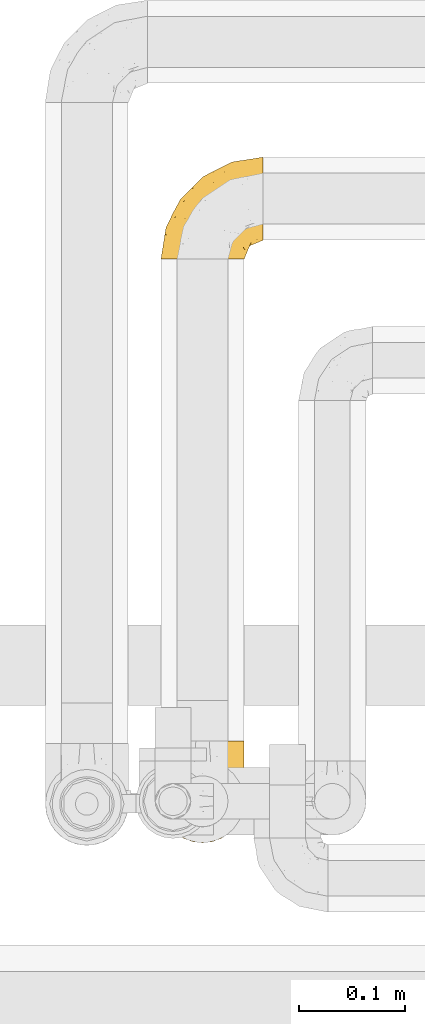
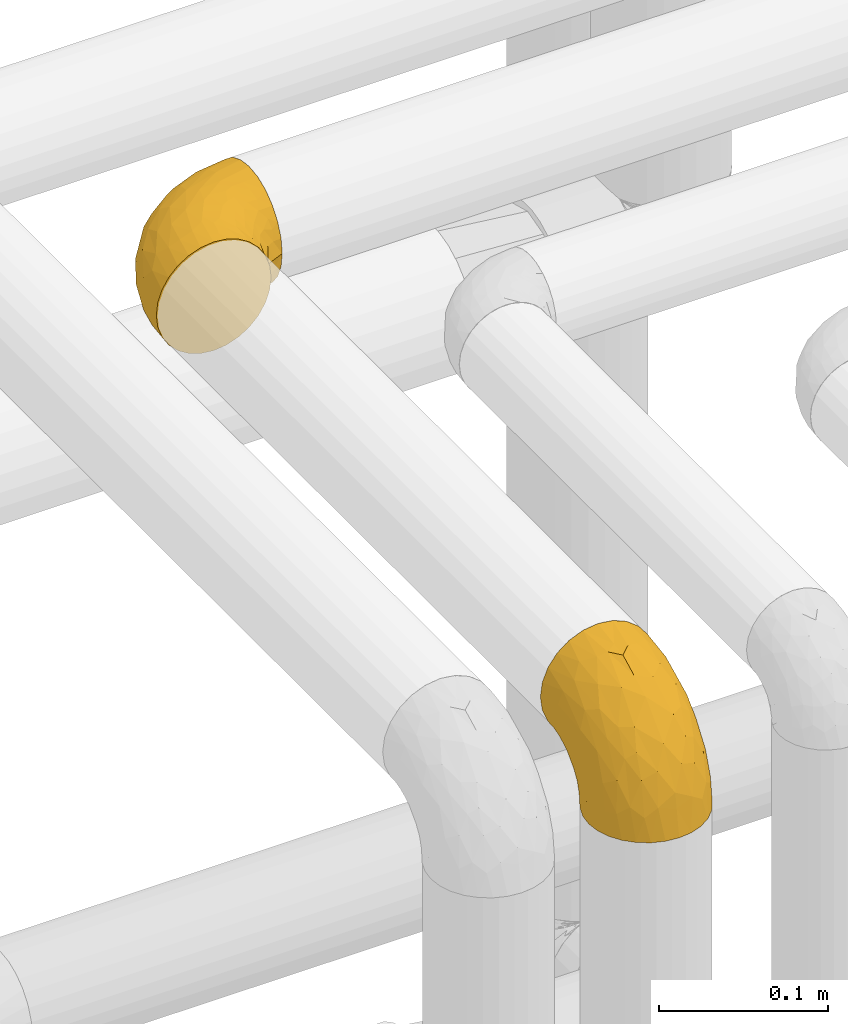
# One storey, part 449 of 827: 2 coverings.
"""IFC2X3 building model written with IfcOpenShell, lengths in millimetres."""

from ifc_helpers import new_model, entity, si_unit, converted_unit, derived_unit, direction, frame, origin, place, context, subcontext, project, spatial, faceted_brep, element, save


model = new_model("IFC2X3")

# Units and contexts
model_context = context("Model", 3, precision=0.01, world=origin(), true_north=direction((6.12303176911189e-17, 1.0)))
body_context = subcontext(model_context, "Body", "Model", "MODEL_VIEW")
ifc_project = project(units=[si_unit("LENGTHUNIT", "METRE", prefix="MILLI"), si_unit("AREAUNIT", "SQUARE_METRE"), si_unit("VOLUMEUNIT", "CUBIC_METRE"), converted_unit("PLANEANGLEUNIT", "DEGREE", entity("IfcRatioMeasure", 0.0174532925199433), si_unit("PLANEANGLEUNIT", "RADIAN"), dimensions=[0, 0, 0, 0, 0, 0, 0]), si_unit("MASSUNIT", "GRAM", prefix="KILO"), derived_unit("MASSDENSITYUNIT", [(si_unit("MASSUNIT", "GRAM", prefix="KILO"), 1), (si_unit("LENGTHUNIT", "METRE"), -3)]), derived_unit("MOMENTOFINERTIAUNIT", [(si_unit("LENGTHUNIT", "METRE"), 4)]), si_unit("TIMEUNIT", "SECOND"), si_unit("FREQUENCYUNIT", "HERTZ"), si_unit("THERMODYNAMICTEMPERATUREUNIT", "DEGREE_CELSIUS"), derived_unit("THERMALTRANSMITTANCEUNIT", [(si_unit("MASSUNIT", "GRAM", prefix="KILO"), 1), (si_unit("THERMODYNAMICTEMPERATUREUNIT", "KELVIN"), -1), (si_unit("TIMEUNIT", "SECOND"), -3)]), derived_unit("VOLUMETRICFLOWRATEUNIT", [(si_unit("LENGTHUNIT", "METRE"), 3), (si_unit("TIMEUNIT", "SECOND"), -1)]), derived_unit("MASSFLOWRATEUNIT", [(si_unit("MASSUNIT", "GRAM", prefix="KILO"), 1), (si_unit("TIMEUNIT", "SECOND"), -1)]), derived_unit("ROTATIONALFREQUENCYUNIT", [(si_unit("TIMEUNIT", "SECOND"), -1)]), si_unit("ELECTRICCURRENTUNIT", "AMPERE"), si_unit("ELECTRICVOLTAGEUNIT", "VOLT"), si_unit("POWERUNIT", "WATT"), si_unit("FORCEUNIT", "NEWTON", prefix="KILO"), si_unit("ILLUMINANCEUNIT", "LUX"), si_unit("LUMINOUSFLUXUNIT", "LUMEN"), si_unit("LUMINOUSINTENSITYUNIT", "CANDELA"), derived_unit("USERDEFINED", [(si_unit("MASSUNIT", "GRAM", prefix="KILO"), -1), (si_unit("LENGTHUNIT", "METRE"), -2), (si_unit("TIMEUNIT", "SECOND"), 3), (si_unit("LUMINOUSFLUXUNIT", "LUMEN"), 1)]), derived_unit("LINEARVELOCITYUNIT", [(si_unit("LENGTHUNIT", "METRE"), 1), (si_unit("TIMEUNIT", "SECOND"), -1)]), si_unit("PRESSUREUNIT", "PASCAL"), derived_unit("USERDEFINED", [(si_unit("LENGTHUNIT", "METRE"), -2), (si_unit("MASSUNIT", "GRAM", prefix="KILO"), 1), (si_unit("TIMEUNIT", "SECOND"), -2)]), derived_unit("LINEARFORCEUNIT", [(si_unit("MASSUNIT", "GRAM", prefix="KILO"), 1), (si_unit("LENGTHUNIT", "METRE"), 1), (si_unit("TIMEUNIT", "SECOND"), -2), (si_unit("LENGTHUNIT", "METRE"), -1)]), derived_unit("PLANARFORCEUNIT", [(si_unit("MASSUNIT", "GRAM", prefix="KILO"), 1), (si_unit("LENGTHUNIT", "METRE"), 1), (si_unit("TIMEUNIT", "SECOND"), -2), (si_unit("LENGTHUNIT", "METRE"), -2)])], contexts=[model_context])

# Site, building, storey
site_placement = place(None, origin())
site = spatial("IfcSite", under=ifc_project, at=site_placement, CompositionType="ELEMENT")
building_placement = place(site_placement, origin())
building = spatial("IfcBuilding", under=site, at=building_placement, CompositionType="ELEMENT")
storey_placement = place(building_placement, frame((0.0, 0.0, 28200.0)))
storey = spatial("IfcBuildingStorey", under=building, at=storey_placement, Name="08", CompositionType="ELEMENT", Elevation=28200.0)

# Coverings
covering_1_placement = place(storey_placement, frame((55802.39, 16779.34, 3159.25)))
element("IfcCovering", 1, at=covering_1_placement, inside=storey, Name=":ADSK_", ObjectType=":ADSK_", PredefinedType="INSULATION", context=body_context, shape_type="Brep", body=[
    faceted_brep([(40.75, 1.6, 79.9), (32.03, 1.6, 78.91), (23.75, 1.6, 76.02), (16.33, 1.6, 71.35), (10.13, 1.6, 65.15), (5.47, 1.6, 57.73), (2.58, 1.6, 49.45), (1.6, 1.6, 40.75), (2.58, 1.6, 32.03), (5.48, 1.6, 23.75), (10.14, 1.6, 16.33), (16.34, 1.6, 10.13), (23.76, 1.6, 5.47), (32.04, 1.6, 2.58), (40.75, 1.6, 1.6), (43.94, 1.6, 1.96), (49.46, 1.6, 2.58), (53.6, 1.6, 4.03), (57.74, 1.6, 5.48), (65.16, 1.6, 10.14), (71.36, 1.6, 16.34), (76.02, 1.6, 23.76), (78.91, 1.6, 32.04), (79.9, 1.6, 40.75), (78.91, 1.6, 49.46), (76.02, 1.6, 57.74), (71.35, 1.6, 65.16), (65.15, 1.6, 71.36), (57.73, 1.6, 76.02), (49.45, 1.6, 78.91), (43.94, 1.6, 79.54), (97.75, 30.91, 13.06), (97.75, 39.02, 6.84), (97.75, 48.46, 2.93), (97.75, 52.18, 2.44), (97.75, 55.39, 2.02), (97.75, 58.6, 1.6), (97.75, 68.73, 2.93), (97.75, 78.17, 6.84), (97.75, 86.28, 13.06), (97.75, 92.5, 21.17), (97.75, 96.41, 30.61), (97.75, 97.75, 40.75), (97.75, 96.41, 50.88), (97.75, 92.5, 60.32), (97.75, 86.28, 68.43), (97.75, 78.17, 74.65), (97.75, 68.73, 78.56), (97.75, 58.6, 79.9), (97.75, 52.18, 79.05), (97.75, 48.46, 78.56), (97.75, 39.02, 74.65), (97.75, 30.91, 68.43), (97.75, 24.69, 60.32), (97.75, 20.78, 50.88), (97.75, 19.45, 40.75), (97.75, 20.78, 30.61), (97.75, 24.69, 21.17), (30.59, 68.75, 40.75), (19.96, 58.11, 40.75), (31.39, 67.95, 53.99), (41.23, 79.38, 40.75), (68.03, 93.04, 40.75), (73.86, 94.13, 47.49), (78.49, 94.7, 40.75), (51.06, 83.92, 51.52), (61.05, 83.74, 61.86), (74.96, 92.46, 54.43), (80.64, 88.89, 63.37), (35.94, 18.55, 79.25), (55.44, 59.47, 77.04), (78.19, 73.43, 75.79), (58.08, 70.77, 72.61), (78.4, 64.34, 78.93), (74.65, 81.19, 70.12), (14.61, 24.77, 66.7), (20.05, 18.96, 72.7), (24.25, 39.69, 70.21), (43.81, 39.98, 78.8), (45.08, 23.41, 79.9), (48.17, 28.03, 79.9), (51.26, 32.65, 79.9), (54.35, 37.28, 79.9), (57.44, 41.9, 79.9), (40.25, 52.71, 74.44), (6.22, 24.51, 52.47), (61.23, 53.67, 79.33), (62.06, 44.99, 79.9), (66.69, 48.08, 79.9), (71.31, 51.17, 79.9), (75.93, 54.26, 79.9), (13.08, 45.31, 48.94), (14.98, 41.19, 58.78), (8.5, 18.54, 60.43), (4.64, 20.85, 40.75), (36.67, 67.52, 62.02), (22.97, 55.82, 57.53), (41.46, 5.17, 79.9), (42.17, 8.74, 79.9), (43.59, 15.88, 79.9), (25.24, 52.18, 64.12), (31.25, 35.23, 75.76), (26.96, 17.8, 76.65), (38.0, 60.91, 68.92), (50.65, 73.89, 66.73), (54.63, 86.21, 40.75), (6.3, 31.31, 40.75), (83.46, 55.75, 79.9), (87.03, 56.46, 79.9), (90.6, 57.17, 79.9), (13.13, 44.71, 40.75), (91.79, 26.29, 63.86), (87.2, 29.74, 69.15), (87.5, 47.68, 78.65), (89.79, 35.46, 72.98), (88.45, 41.52, 76.47), (81.77, 40.21, 76.82), (79.81, 47.09, 79.05), (73.84, 44.48, 79.09), (91.84, 19.96, 51.28), (86.62, 17.27, 51.03), (85.12, 14.22, 40.75), (91.15, 16.71, 40.75), (80.84, 10.14, 49.93), (78.96, 13.28, 58.53), (71.38, 17.56, 69.86), (76.81, 17.71, 65.19), (74.29, 23.15, 70.75), (48.29, 8.48, 79.25), (49.97, 13.45, 79.11), (92.85, 22.84, 57.89), (77.55, 7.02, 55.93), (62.05, 29.23, 78.06), (70.85, 29.51, 75.39), (65.52, 33.67, 78.16), (80.71, 23.34, 66.62), (77.97, 30.5, 73.14), (66.14, 7.97, 71.07), (57.01, 22.97, 78.32), (64.57, 16.17, 73.93), (56.53, 13.36, 77.25), (51.07, 19.39, 79.26), (81.85, 18.33, 60.3), (82.63, 8.19, 40.75), (72.53, 10.82, 65.72), (67.69, 23.48, 74.5), (86.44, 21.93, 60.62), (82.44, 34.48, 73.96), (75.97, 38.65, 77.3), (70.39, 36.64, 77.83), (92.85, 22.84, 23.6), (88.99, 25.49, 17.57), (41.46, 5.17, 1.6), (42.17, 8.74, 1.6), (43.59, 15.88, 1.6), (80.84, 10.14, 31.57), (78.97, 13.28, 22.97), (77.55, 7.02, 25.57), (72.54, 10.82, 15.78), (83.46, 55.75, 1.6), (90.6, 57.17, 1.6), (94.17, 57.88, 1.6), (87.2, 29.74, 12.34), (82.6, 34.5, 7.57), (89.34, 34.84, 8.85), (80.74, 46.53, 2.63), (81.77, 40.21, 4.67), (74.04, 44.84, 2.36), (75.93, 54.26, 1.6), (87.5, 47.68, 2.84), (51.07, 19.39, 2.24), (48.17, 28.03, 1.6), (57.03, 22.96, 3.18), (74.31, 23.16, 10.74), (80.61, 22.9, 15.18), (77.09, 17.91, 16.42), (91.84, 19.96, 30.21), (79.19, 28.63, 9.98), (86.62, 17.27, 30.46), (66.15, 7.97, 10.43), (71.84, 17.45, 12.05), (56.55, 13.36, 4.24), (64.59, 16.17, 7.56), (62.05, 29.23, 3.43), (49.99, 13.44, 2.38), (45.08, 23.41, 1.6), (70.39, 36.64, 3.66), (76.36, 38.11, 4.45), (67.71, 23.51, 6.98), (70.92, 29.52, 6.12), (89.33, 40.9, 5.38), (82.04, 18.21, 21.58), (51.26, 32.65, 1.6), (86.44, 21.93, 20.87), (65.56, 33.63, 3.35), (62.06, 44.99, 1.6), (57.44, 41.9, 1.6), (54.35, 37.28, 1.6), (71.31, 51.17, 1.6), (66.69, 48.08, 1.6), (61.23, 53.67, 2.16), (74.65, 81.19, 11.37), (78.19, 73.43, 5.7), (58.07, 70.76, 8.88), (38.01, 60.91, 12.57), (40.25, 52.7, 7.04), (24.26, 39.68, 11.27), (25.25, 52.18, 17.36), (43.81, 39.98, 2.69), (78.4, 64.34, 2.56), (73.86, 94.13, 34.0), (74.96, 92.46, 27.06), (55.45, 59.46, 4.45), (31.26, 35.22, 5.73), (80.64, 88.89, 18.12), (61.05, 83.74, 19.63), (31.39, 67.95, 27.49), (36.69, 67.52, 19.46), (35.95, 18.55, 2.24), (6.22, 24.51, 29.01), (14.62, 24.77, 14.78), (13.09, 45.32, 32.55), (20.06, 18.96, 8.78), (51.06, 83.92, 29.98), (22.97, 55.82, 23.95), (14.99, 41.19, 22.7), (8.51, 18.54, 21.05), (50.64, 73.87, 14.75), (26.97, 17.8, 4.84)], [[[0, 1, 2, 3, 4, 5, 6, 7, 8, 9, 10, 11, 12, 13, 14, 15, 16, 17, 18, 19, 20, 21, 22, 23, 24, 25, 26, 27, 28, 29, 30]], [[31, 32, 33, 34, 35, 36, 37, 38, 39, 40, 41, 42, 43, 44, 45, 46, 47, 48, 49, 50, 51, 52, 53, 54, 55, 56, 57]], [[58, 59, 60, 61]], [[62, 63, 64]], [[65, 66, 67]], [[67, 66, 68]], [[69, 1, 0]], [[70, 71, 72]], [[44, 43, 67]], [[47, 71, 73]], [[45, 74, 46]], [[68, 45, 44]], [[75, 76, 77]], [[76, 3, 2]], [[78, 79, 80, 81, 82, 83]], [[48, 47, 73]], [[70, 72, 84]], [[5, 85, 6]], [[86, 83, 87, 88, 89, 90]], [[91, 85, 92]], [[76, 75, 3]], [[71, 46, 74]], [[85, 5, 93]], [[45, 68, 74]], [[5, 4, 93]], [[85, 94, 6]], [[86, 78, 83]], [[60, 95, 65]], [[96, 95, 60]], [[75, 4, 3]], [[69, 0, 97, 98, 99, 79]], [[75, 77, 100]], [[43, 64, 63]], [[101, 102, 69]], [[101, 76, 102]], [[46, 71, 47]], [[95, 103, 104]], [[92, 85, 93]], [[63, 105, 65]], [[92, 75, 100]], [[91, 106, 85]], [[84, 78, 70]], [[67, 68, 44]], [[65, 67, 63]], [[65, 61, 60]], [[4, 75, 93]], [[92, 93, 75]], [[102, 76, 2]], [[77, 76, 101]], [[84, 77, 101]], [[77, 103, 100]], [[72, 71, 74]], [[70, 86, 73]], [[104, 74, 66]], [[84, 72, 103]], [[70, 73, 71]], [[73, 90, 107, 108, 109, 48]], [[79, 78, 69]], [[101, 69, 78]], [[91, 92, 96]], [[91, 59, 110, 106]], [[2, 1, 102]], [[69, 102, 1]], [[94, 85, 106]], [[94, 7, 6]], [[74, 68, 66]], [[43, 42, 64]], [[43, 63, 67]], [[73, 86, 90]], [[78, 86, 70]], [[95, 100, 103]], [[96, 92, 100]], [[104, 103, 72]], [[65, 95, 66]], [[74, 104, 72]], [[66, 95, 104]], [[95, 96, 100]], [[91, 96, 60]], [[77, 84, 103]], [[78, 84, 101]], [[60, 59, 91]], [[105, 63, 62]], [[105, 61, 65]], [[111, 52, 112]], [[107, 90, 113]], [[114, 115, 116]], [[50, 107, 113]], [[117, 118, 116]], [[54, 119, 55]], [[97, 0, 30, 29, 98]], [[113, 115, 51]], [[120, 121, 122]], [[123, 120, 124]], [[125, 126, 127]], [[128, 28, 129]], [[130, 54, 53]], [[25, 24, 131]], [[132, 133, 134]], [[135, 112, 136]], [[137, 27, 26]], [[121, 120, 123]], [[138, 139, 132]], [[129, 140, 141]], [[135, 126, 142]], [[27, 140, 28]], [[27, 137, 140]], [[49, 48, 109, 108, 107, 50]], [[23, 143, 121, 123]], [[25, 131, 144]], [[26, 25, 144]], [[128, 98, 29]], [[125, 127, 145]], [[146, 130, 111]], [[137, 144, 139]], [[139, 138, 140]], [[116, 147, 114]], [[123, 124, 131]], [[116, 118, 148]], [[138, 132, 81]], [[129, 79, 99]], [[54, 130, 119]], [[141, 79, 129]], [[122, 55, 119]], [[120, 146, 142]], [[117, 113, 90]], [[50, 113, 51]], [[127, 133, 145]], [[147, 136, 112]], [[136, 133, 127]], [[24, 23, 123]], [[118, 117, 89]], [[149, 87, 134]], [[144, 131, 124]], [[24, 123, 131]], [[128, 129, 99]], [[28, 140, 129]], [[144, 137, 26]], [[140, 137, 139]], [[134, 82, 132]], [[138, 80, 141]], [[89, 88, 87, 118]], [[115, 117, 116]], [[140, 138, 141]], [[148, 118, 149]], [[136, 148, 149]], [[147, 116, 148]], [[133, 136, 149]], [[127, 126, 135]], [[136, 147, 148]], [[114, 112, 52]], [[112, 114, 147]], [[51, 114, 52]], [[51, 115, 114]], [[117, 115, 113]], [[117, 90, 89]], [[134, 133, 149]], [[145, 133, 132]], [[132, 139, 145]], [[125, 139, 144]], [[139, 125, 145]], [[126, 144, 124]], [[144, 126, 125]], [[142, 126, 124]], [[120, 142, 124]], [[142, 146, 135]], [[112, 135, 146]], [[136, 127, 135]], [[118, 87, 149]], [[111, 130, 53]], [[119, 146, 120]], [[146, 119, 130]], [[122, 119, 120]], [[52, 111, 53]], [[146, 111, 112]], [[82, 134, 83]], [[82, 81, 132]], [[83, 134, 87]], [[98, 128, 99]], [[80, 138, 81]], [[80, 79, 141]], [[28, 128, 29]], [[150, 151, 57]], [[15, 14, 152, 153, 154, 16]], [[121, 143, 23, 155]], [[150, 57, 56]], [[156, 157, 158]], [[35, 34, 33, 159, 160, 161, 36]], [[162, 31, 57]], [[163, 164, 162]], [[165, 166, 167]], [[155, 23, 22]], [[168, 159, 169]], [[170, 171, 172]], [[173, 174, 175]], [[55, 122, 176]], [[177, 174, 173]], [[22, 157, 155]], [[178, 121, 155]], [[169, 33, 32]], [[20, 19, 179]], [[21, 20, 158]], [[158, 180, 175]], [[181, 182, 179]], [[172, 183, 182]], [[122, 121, 178]], [[181, 19, 18]], [[184, 185, 170]], [[17, 154, 184]], [[186, 187, 177]], [[187, 186, 167]], [[179, 158, 20]], [[21, 157, 22]], [[175, 180, 173]], [[188, 189, 173]], [[164, 166, 190]], [[185, 184, 154]], [[181, 172, 182]], [[156, 191, 178]], [[192, 183, 172]], [[178, 176, 122]], [[193, 150, 176]], [[33, 169, 159]], [[190, 169, 32]], [[189, 194, 186]], [[180, 188, 173]], [[167, 166, 187]], [[166, 164, 163]], [[195, 194, 196]], [[158, 157, 21]], [[155, 157, 156]], [[178, 155, 156]], [[181, 18, 184]], [[17, 16, 154]], [[181, 179, 19]], [[158, 179, 182]], [[170, 181, 184]], [[196, 194, 197]], [[31, 190, 32]], [[165, 190, 166]], [[190, 31, 164]], [[31, 162, 164]], [[177, 163, 162]], [[187, 166, 163]], [[151, 174, 177]], [[177, 173, 189]], [[177, 187, 163]], [[195, 167, 186]], [[165, 198, 168]], [[165, 168, 169]], [[167, 198, 165]], [[190, 165, 169]], [[167, 195, 199, 198]], [[151, 177, 162]], [[175, 191, 156]], [[191, 174, 193]], [[158, 175, 156]], [[174, 191, 175]], [[178, 191, 193]], [[158, 182, 180]], [[188, 182, 183]], [[182, 188, 180]], [[183, 194, 189]], [[183, 189, 188]], [[177, 189, 186]], [[194, 183, 197]], [[176, 150, 56]], [[151, 150, 193]], [[176, 56, 55]], [[193, 176, 178]], [[174, 151, 193]], [[57, 151, 162]], [[183, 192, 197]], [[194, 195, 186]], [[171, 192, 172]], [[172, 181, 170]], [[170, 185, 171]], [[184, 18, 17]], [[200, 168, 198, 199, 195, 196]], [[201, 202, 203]], [[204, 203, 205]], [[204, 206, 207]], [[208, 196, 197, 192, 171, 185]], [[209, 36, 161, 160, 159, 168]], [[202, 38, 37]], [[201, 38, 202]], [[210, 41, 211]], [[200, 208, 212]], [[205, 208, 213]], [[214, 211, 40]], [[40, 211, 41]], [[214, 201, 215]], [[58, 61, 216, 59]], [[201, 39, 38]], [[207, 217, 204]], [[213, 208, 218]], [[218, 185, 154, 153, 152, 14]], [[14, 13, 218]], [[9, 8, 219]], [[10, 220, 11]], [[221, 106, 110, 59]], [[219, 8, 94]], [[220, 222, 11]], [[223, 211, 215]], [[221, 216, 224]], [[225, 219, 221]], [[10, 9, 226]], [[213, 222, 206]], [[226, 9, 219]], [[106, 219, 94]], [[212, 202, 209]], [[201, 203, 227]], [[226, 225, 220]], [[207, 206, 220]], [[214, 40, 39]], [[11, 222, 12]], [[12, 222, 228]], [[41, 210, 64]], [[223, 105, 210]], [[223, 215, 217]], [[105, 62, 210]], [[206, 222, 220]], [[228, 222, 213]], [[207, 220, 225]], [[205, 206, 204]], [[225, 226, 219]], [[220, 10, 226]], [[209, 202, 37]], [[203, 202, 212]], [[205, 203, 212]], [[204, 217, 227]], [[36, 209, 37]], [[209, 168, 200]], [[218, 13, 228]], [[208, 185, 218]], [[106, 221, 219]], [[221, 59, 216]], [[218, 228, 213]], [[13, 12, 228]], [[8, 7, 94]], [[201, 214, 39]], [[211, 214, 215]], [[64, 210, 62]], [[64, 42, 41]], [[223, 210, 211]], [[208, 200, 196]], [[209, 200, 212]], [[225, 224, 207]], [[207, 224, 217]], [[223, 217, 216]], [[204, 227, 203]], [[217, 215, 227]], [[201, 227, 215]], [[221, 224, 225]], [[217, 224, 216]], [[208, 205, 212]], [[206, 205, 213]], [[216, 61, 223]], [[223, 61, 105]]]),
])
covering_2_placement = place(storey_placement, frame((55802.39, 16229.69, 3141.4)))
element("IfcCovering", 2, at=covering_2_placement, inside=storey, Name=":ADSK_", ObjectType=":ADSK_", PredefinedType="INSULATION", context=body_context, shape_type="Brep", body=[
    faceted_brep([(79.9, 40.75, 1.6), (78.91, 32.03, 1.6), (76.02, 23.75, 1.6), (71.35, 16.33, 1.6), (65.15, 10.13, 1.6), (57.73, 5.47, 1.6), (49.45, 2.58, 1.6), (40.75, 1.6, 1.6), (32.03, 2.58, 1.6), (23.75, 5.48, 1.6), (16.33, 10.14, 1.6), (10.13, 16.34, 1.6), (5.47, 23.76, 1.6), (2.58, 32.04, 1.6), (1.6, 40.75, 1.6), (1.96, 43.94, 1.6), (2.58, 49.46, 1.6), (4.03, 53.6, 1.6), (5.48, 57.74, 1.6), (10.14, 65.16, 1.6), (16.34, 71.36, 1.6), (23.76, 76.02, 1.6), (32.04, 78.91, 1.6), (40.75, 79.9, 1.6), (49.46, 78.91, 1.6), (57.74, 76.02, 1.6), (65.16, 71.35, 1.6), (71.36, 65.15, 1.6), (76.02, 57.73, 1.6), (78.91, 49.45, 1.6), (79.54, 43.94, 1.6), (13.06, 97.75, 30.91), (6.84, 97.75, 39.02), (2.93, 97.75, 48.46), (2.44, 97.75, 52.18), (2.02, 97.75, 55.39), (1.6, 97.75, 58.6), (2.93, 97.75, 68.73), (6.84, 97.75, 78.17), (13.06, 97.75, 86.28), (21.17, 97.75, 92.5), (30.61, 97.75, 96.41), (40.75, 97.75, 97.75), (50.88, 97.75, 96.41), (60.32, 97.75, 92.5), (68.43, 97.75, 86.28), (74.65, 97.75, 78.17), (78.56, 97.75, 68.73), (79.9, 97.75, 58.6), (79.05, 97.75, 52.18), (78.56, 97.75, 48.46), (74.65, 97.75, 39.02), (68.43, 97.75, 30.91), (60.32, 97.75, 24.69), (50.88, 97.75, 20.78), (40.75, 97.75, 19.45), (30.61, 97.75, 20.78), (21.17, 97.75, 24.69), (40.75, 30.59, 68.75), (40.75, 19.96, 58.11), (53.99, 31.39, 67.95), (40.75, 41.23, 79.38), (40.75, 68.03, 93.04), (47.49, 73.86, 94.13), (40.75, 78.49, 94.7), (51.52, 51.06, 83.92), (61.86, 61.05, 83.74), (54.43, 74.96, 92.46), (63.37, 80.64, 88.89), (79.25, 35.94, 18.55), (77.04, 55.44, 59.47), (75.79, 78.19, 73.43), (72.61, 58.08, 70.77), (78.93, 78.4, 64.34), (70.12, 74.65, 81.19), (66.7, 14.61, 24.77), (72.7, 20.05, 18.96), (70.21, 24.25, 39.69), (78.8, 43.81, 39.98), (79.9, 45.08, 23.41), (79.9, 48.17, 28.03), (79.9, 51.26, 32.65), (79.9, 54.35, 37.28), (79.9, 57.44, 41.9), (74.44, 40.25, 52.71), (52.47, 6.22, 24.51), (79.33, 61.23, 53.67), (79.9, 62.06, 44.99), (79.9, 66.69, 48.08), (79.9, 71.31, 51.17), (79.9, 75.93, 54.26), (48.94, 13.08, 45.31), (58.78, 14.98, 41.19), (60.43, 8.5, 18.54), (40.75, 4.64, 20.85), (62.02, 36.67, 67.52), (57.53, 22.97, 55.82), (79.9, 41.46, 5.17), (79.9, 42.17, 8.74), (79.9, 43.59, 15.88), (64.12, 25.24, 52.18), (75.76, 31.25, 35.23), (76.65, 26.96, 17.8), (68.92, 38.0, 60.91), (66.73, 50.65, 73.89), (40.75, 54.63, 86.21), (40.75, 6.3, 31.31), (79.9, 83.46, 55.75), (79.9, 87.03, 56.46), (79.9, 90.6, 57.17), (40.75, 13.13, 44.71), (63.86, 91.79, 26.29), (69.15, 87.2, 29.74), (78.65, 87.5, 47.68), (72.98, 89.79, 35.46), (76.47, 88.45, 41.52), (76.82, 81.77, 40.21), (79.05, 79.81, 47.09), (79.09, 73.84, 44.48), (51.28, 91.84, 19.96), (51.03, 86.62, 17.27), (40.75, 85.12, 14.22), (40.75, 91.15, 16.71), (49.93, 80.84, 10.14), (58.53, 78.96, 13.28), (69.86, 71.38, 17.56), (65.19, 76.81, 17.71), (70.75, 74.29, 23.15), (79.25, 48.29, 8.48), (79.11, 49.97, 13.45), (57.89, 92.85, 22.84), (55.93, 77.55, 7.02), (78.06, 62.05, 29.23), (75.39, 70.85, 29.51), (78.16, 65.52, 33.67), (66.62, 80.71, 23.34), (73.14, 77.97, 30.5), (71.07, 66.14, 7.97), (78.32, 57.01, 22.97), (73.93, 64.57, 16.17), (77.25, 56.53, 13.36), (79.26, 51.07, 19.39), (60.3, 81.85, 18.33), (40.75, 82.63, 8.19), (65.72, 72.53, 10.82), (74.5, 67.69, 23.48), (60.62, 86.44, 21.93), (73.96, 82.44, 34.48), (77.3, 75.97, 38.65), (77.83, 70.39, 36.64), (23.6, 92.85, 22.84), (17.57, 88.99, 25.49), (1.6, 41.46, 5.17), (1.6, 42.17, 8.74), (1.6, 43.59, 15.88), (31.57, 80.84, 10.14), (22.97, 78.97, 13.28), (25.57, 77.55, 7.02), (15.78, 72.54, 10.82), (1.6, 83.46, 55.75), (1.6, 90.6, 57.17), (1.6, 94.17, 57.88), (12.34, 87.2, 29.74), (7.57, 82.6, 34.5), (8.85, 89.34, 34.84), (2.63, 80.74, 46.53), (4.67, 81.77, 40.21), (2.36, 74.04, 44.84), (1.6, 75.93, 54.26), (2.84, 87.5, 47.68), (2.24, 51.07, 19.39), (1.6, 48.17, 28.03), (3.18, 57.03, 22.96), (10.74, 74.31, 23.16), (15.18, 80.61, 22.9), (16.42, 77.09, 17.91), (30.21, 91.84, 19.96), (9.98, 79.19, 28.63), (30.46, 86.62, 17.27), (10.43, 66.15, 7.97), (12.05, 71.84, 17.45), (4.24, 56.55, 13.36), (7.56, 64.59, 16.17), (3.43, 62.05, 29.23), (2.38, 49.99, 13.44), (1.6, 45.08, 23.41), (3.66, 70.39, 36.64), (4.45, 76.36, 38.11), (6.98, 67.71, 23.51), (6.12, 70.92, 29.52), (5.38, 89.33, 40.9), (21.58, 82.04, 18.21), (1.6, 51.26, 32.65), (20.87, 86.44, 21.93), (3.35, 65.56, 33.63), (1.6, 62.06, 44.99), (1.6, 57.44, 41.9), (1.6, 54.35, 37.28), (1.6, 71.31, 51.17), (1.6, 66.69, 48.08), (2.16, 61.23, 53.67), (11.37, 74.65, 81.19), (5.7, 78.19, 73.43), (8.88, 58.07, 70.76), (12.57, 38.01, 60.91), (7.04, 40.25, 52.7), (11.27, 24.26, 39.68), (17.36, 25.25, 52.18), (2.69, 43.81, 39.98), (2.56, 78.4, 64.34), (34.0, 73.86, 94.13), (27.06, 74.96, 92.46), (4.45, 55.45, 59.46), (5.73, 31.26, 35.22), (18.12, 80.64, 88.89), (19.63, 61.05, 83.74), (27.49, 31.39, 67.95), (19.46, 36.69, 67.52), (2.24, 35.95, 18.55), (29.01, 6.22, 24.51), (14.78, 14.62, 24.77), (32.55, 13.09, 45.32), (8.78, 20.06, 18.96), (29.98, 51.06, 83.92), (23.95, 22.97, 55.82), (22.7, 14.99, 41.19), (21.05, 8.51, 18.54), (14.75, 50.64, 73.87), (4.84, 26.97, 17.8)], [[[0, 1, 2, 3, 4, 5, 6, 7, 8, 9, 10, 11, 12, 13, 14, 15, 16, 17, 18, 19, 20, 21, 22, 23, 24, 25, 26, 27, 28, 29, 30]], [[31, 32, 33, 34, 35, 36, 37, 38, 39, 40, 41, 42, 43, 44, 45, 46, 47, 48, 49, 50, 51, 52, 53, 54, 55, 56, 57]], [[58, 59, 60, 61]], [[62, 63, 64]], [[65, 66, 67]], [[67, 66, 68]], [[69, 1, 0]], [[70, 71, 72]], [[44, 43, 67]], [[47, 71, 73]], [[45, 74, 46]], [[68, 45, 44]], [[75, 76, 77]], [[76, 3, 2]], [[78, 79, 80, 81, 82, 83]], [[48, 47, 73]], [[70, 72, 84]], [[5, 85, 6]], [[86, 83, 87, 88, 89, 90]], [[91, 85, 92]], [[76, 75, 3]], [[71, 46, 74]], [[85, 5, 93]], [[45, 68, 74]], [[5, 4, 93]], [[85, 94, 6]], [[86, 78, 83]], [[60, 95, 65]], [[96, 95, 60]], [[75, 4, 3]], [[69, 0, 97, 98, 99, 79]], [[75, 77, 100]], [[43, 64, 63]], [[101, 102, 69]], [[101, 76, 102]], [[46, 71, 47]], [[95, 103, 104]], [[92, 85, 93]], [[63, 105, 65]], [[92, 75, 100]], [[91, 106, 85]], [[84, 78, 70]], [[67, 68, 44]], [[65, 67, 63]], [[65, 61, 60]], [[4, 75, 93]], [[92, 93, 75]], [[102, 76, 2]], [[77, 76, 101]], [[84, 77, 101]], [[77, 103, 100]], [[72, 71, 74]], [[70, 86, 73]], [[104, 74, 66]], [[84, 72, 103]], [[70, 73, 71]], [[73, 90, 107, 108, 109, 48]], [[79, 78, 69]], [[101, 69, 78]], [[91, 92, 96]], [[91, 59, 110, 106]], [[2, 1, 102]], [[69, 102, 1]], [[94, 85, 106]], [[94, 7, 6]], [[74, 68, 66]], [[43, 42, 64]], [[43, 63, 67]], [[73, 86, 90]], [[78, 86, 70]], [[95, 100, 103]], [[96, 92, 100]], [[104, 103, 72]], [[65, 95, 66]], [[74, 104, 72]], [[66, 95, 104]], [[95, 96, 100]], [[91, 96, 60]], [[77, 84, 103]], [[78, 84, 101]], [[60, 59, 91]], [[105, 63, 62]], [[105, 61, 65]], [[111, 52, 112]], [[107, 90, 113]], [[114, 115, 116]], [[50, 107, 113]], [[117, 118, 116]], [[54, 119, 55]], [[97, 0, 30, 29, 98]], [[113, 115, 51]], [[120, 121, 122]], [[123, 120, 124]], [[125, 126, 127]], [[128, 28, 129]], [[130, 54, 53]], [[25, 24, 131]], [[132, 133, 134]], [[135, 112, 136]], [[137, 27, 26]], [[121, 120, 123]], [[138, 139, 132]], [[129, 140, 141]], [[135, 126, 142]], [[27, 140, 28]], [[27, 137, 140]], [[49, 48, 109, 108, 107, 50]], [[23, 143, 121, 123]], [[25, 131, 144]], [[26, 25, 144]], [[128, 98, 29]], [[125, 127, 145]], [[146, 130, 111]], [[137, 144, 139]], [[139, 138, 140]], [[116, 147, 114]], [[123, 124, 131]], [[116, 118, 148]], [[134, 83, 82]], [[129, 79, 99]], [[54, 130, 119]], [[141, 79, 129]], [[122, 55, 119]], [[120, 146, 142]], [[117, 113, 90]], [[50, 113, 51]], [[127, 133, 145]], [[147, 136, 112]], [[136, 133, 127]], [[24, 23, 123]], [[118, 117, 89]], [[149, 87, 134]], [[144, 131, 124]], [[24, 123, 131]], [[128, 129, 99]], [[28, 140, 129]], [[144, 137, 26]], [[140, 137, 139]], [[81, 138, 132]], [[138, 80, 141]], [[89, 88, 87, 118]], [[115, 117, 116]], [[140, 138, 141]], [[148, 118, 149]], [[136, 148, 149]], [[147, 116, 148]], [[133, 136, 149]], [[127, 126, 135]], [[136, 147, 148]], [[114, 112, 52]], [[112, 114, 147]], [[51, 114, 52]], [[51, 115, 114]], [[117, 115, 113]], [[117, 90, 89]], [[134, 133, 149]], [[145, 133, 132]], [[132, 139, 145]], [[125, 139, 144]], [[139, 125, 145]], [[126, 144, 124]], [[144, 126, 125]], [[142, 126, 124]], [[120, 142, 124]], [[142, 146, 135]], [[112, 135, 146]], [[136, 127, 135]], [[118, 87, 149]], [[82, 81, 132]], [[111, 130, 53]], [[119, 146, 120]], [[146, 119, 130]], [[122, 119, 120]], [[52, 111, 53]], [[146, 111, 112]], [[134, 82, 132]], [[83, 134, 87]], [[98, 128, 99]], [[80, 138, 81]], [[80, 79, 141]], [[28, 128, 29]], [[150, 151, 57]], [[15, 14, 152, 153, 154, 16]], [[121, 143, 23, 155]], [[150, 57, 56]], [[156, 157, 158]], [[35, 34, 33, 159, 160, 161, 36]], [[162, 31, 57]], [[163, 164, 162]], [[165, 166, 167]], [[155, 23, 22]], [[168, 159, 169]], [[170, 171, 172]], [[173, 174, 175]], [[55, 122, 176]], [[177, 174, 173]], [[22, 157, 155]], [[178, 121, 155]], [[169, 33, 32]], [[20, 19, 179]], [[21, 20, 158]], [[158, 180, 175]], [[181, 182, 179]], [[172, 183, 182]], [[122, 121, 178]], [[181, 19, 18]], [[184, 185, 170]], [[17, 154, 184]], [[186, 187, 177]], [[187, 186, 167]], [[179, 158, 20]], [[21, 157, 22]], [[175, 180, 173]], [[188, 189, 173]], [[164, 166, 190]], [[185, 184, 154]], [[181, 172, 182]], [[156, 191, 178]], [[192, 183, 172]], [[178, 176, 122]], [[193, 150, 176]], [[33, 169, 159]], [[190, 169, 32]], [[189, 194, 186]], [[180, 188, 173]], [[167, 166, 187]], [[166, 164, 163]], [[195, 194, 196]], [[158, 157, 21]], [[155, 157, 156]], [[178, 155, 156]], [[181, 18, 184]], [[17, 16, 154]], [[181, 179, 19]], [[158, 179, 182]], [[170, 181, 184]], [[196, 194, 197]], [[31, 190, 32]], [[165, 190, 166]], [[190, 31, 164]], [[31, 162, 164]], [[177, 163, 162]], [[187, 166, 163]], [[151, 174, 177]], [[177, 173, 189]], [[177, 187, 163]], [[195, 167, 186]], [[165, 198, 168]], [[165, 168, 169]], [[167, 198, 165]], [[190, 165, 169]], [[167, 195, 199, 198]], [[151, 177, 162]], [[175, 191, 156]], [[191, 174, 193]], [[158, 175, 156]], [[174, 191, 175]], [[178, 191, 193]], [[158, 182, 180]], [[188, 182, 183]], [[182, 188, 180]], [[183, 194, 189]], [[183, 189, 188]], [[177, 189, 186]], [[194, 183, 197]], [[176, 150, 56]], [[151, 150, 193]], [[176, 56, 55]], [[193, 176, 178]], [[174, 151, 193]], [[57, 151, 162]], [[183, 192, 197]], [[194, 195, 186]], [[171, 192, 172]], [[172, 181, 170]], [[170, 185, 171]], [[184, 18, 17]], [[200, 168, 198, 199, 195, 196]], [[201, 202, 203]], [[204, 203, 205]], [[204, 206, 207]], [[208, 196, 197, 192, 171, 185]], [[209, 36, 161, 160, 159, 168]], [[202, 38, 37]], [[201, 38, 202]], [[210, 41, 211]], [[200, 208, 212]], [[205, 208, 213]], [[214, 211, 40]], [[40, 211, 41]], [[214, 201, 215]], [[58, 61, 216, 59]], [[201, 39, 38]], [[207, 217, 204]], [[213, 208, 218]], [[218, 185, 154, 153, 152, 14]], [[14, 13, 218]], [[9, 8, 219]], [[10, 220, 11]], [[221, 106, 110, 59]], [[219, 8, 94]], [[220, 222, 11]], [[223, 211, 215]], [[221, 216, 224]], [[225, 219, 221]], [[10, 9, 226]], [[213, 222, 206]], [[226, 9, 219]], [[106, 219, 94]], [[212, 202, 209]], [[201, 203, 227]], [[226, 225, 220]], [[207, 206, 220]], [[214, 40, 39]], [[11, 222, 12]], [[12, 222, 228]], [[41, 210, 64]], [[223, 105, 210]], [[223, 215, 217]], [[105, 62, 210]], [[206, 222, 220]], [[228, 222, 213]], [[207, 220, 225]], [[205, 206, 204]], [[225, 226, 219]], [[220, 10, 226]], [[209, 202, 37]], [[203, 202, 212]], [[205, 203, 212]], [[204, 217, 227]], [[36, 209, 37]], [[209, 168, 200]], [[218, 13, 228]], [[208, 185, 218]], [[106, 221, 219]], [[221, 59, 216]], [[218, 228, 213]], [[13, 12, 228]], [[8, 7, 94]], [[201, 214, 39]], [[211, 214, 215]], [[64, 210, 62]], [[64, 42, 41]], [[223, 210, 211]], [[208, 200, 196]], [[209, 200, 212]], [[225, 224, 207]], [[207, 224, 217]], [[223, 217, 216]], [[204, 227, 203]], [[217, 215, 227]], [[201, 227, 215]], [[221, 224, 225]], [[217, 224, 216]], [[208, 205, 212]], [[206, 205, 213]], [[216, 61, 223]], [[223, 61, 105]]]),
])

save(model, "model.ifc")
